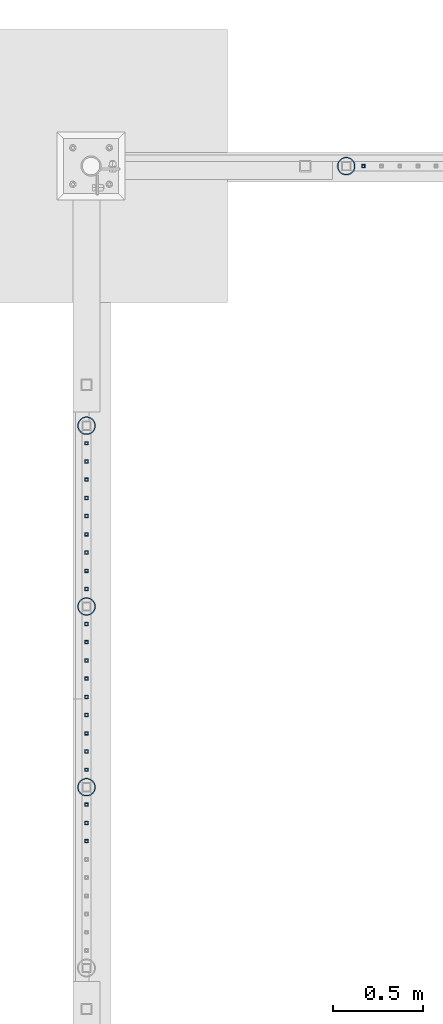
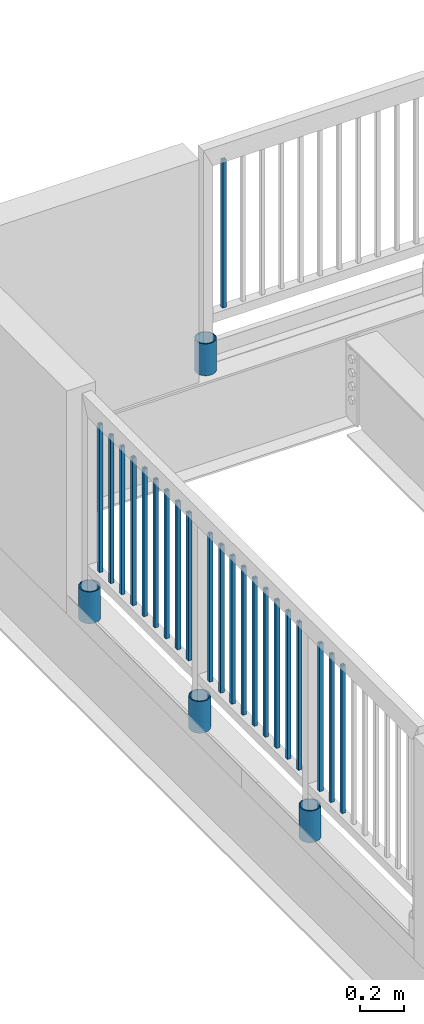
# One storey, part 230 of 975: 26 columns.
"""IFC2X3 building model written with IfcOpenShell, lengths in millimetres."""

from ifc_helpers import new_model, si_unit, frame, origin_with_axes, place, context, subcontext, project, spatial, faceted_brep, material, type_object, element, save


model = new_model("IFC2X3")

# Units and contexts
model_context = context("Model", 3, precision=1e-05, world=origin_with_axes())
body_context = subcontext(model_context, "Body", "Model", "MODEL_VIEW")
ifc_project = project(units=[si_unit("LENGTHUNIT", "METRE", prefix="MILLI"), si_unit("AREAUNIT", "SQUARE_METRE"), si_unit("VOLUMEUNIT", "CUBIC_METRE"), si_unit("MASSUNIT", "GRAM", prefix="KILO"), si_unit("TIMEUNIT", "SECOND"), si_unit("PLANEANGLEUNIT", "RADIAN"), si_unit("SOLIDANGLEUNIT", "STERADIAN"), si_unit("THERMODYNAMICTEMPERATUREUNIT", "DEGREE_CELSIUS"), si_unit("LUMINOUSINTENSITYUNIT", "LUMEN")], contexts=[model_context])

# Site, building, storey
site_placement = place(None, origin_with_axes())
site = spatial("IfcSite", under=ifc_project, at=site_placement, CompositionType="ELEMENT")
building_placement = place(site_placement, origin_with_axes())
building = spatial("IfcBuilding", under=site, at=building_placement, Name="Undefined", CompositionType="ELEMENT")
storey_placement = place(building_placement, origin_with_axes())
storey = spatial("IfcBuildingStorey", under=building, at=storey_placement, Name="Undefined", CompositionType="ELEMENT", Elevation=0.0)

# Columns
ifc_material_1 = material()
column_type_1 = type_object("IfcColumnType", Name="HSS3/4X3/4X.120_TUBES", PredefinedType="NOTDEFINED")
for number, where, z_axis, x_axis, name in (
    (1, (2092.38575337473, 28417.3088163748, 4254.49988162489), (0.0, 1.0, 0.0), (0.0, 0.0, 1.0), "PICKET"),
    (2, (2092.38575337473, 28315.7088163748, 4254.49988162489), (0.0, 1.0, 0.0), (0.0, 0.0, 1.0), "PICKET"),
    (3, (2092.38575337473, 28214.1088163748, 4254.49988162489), (0.0, 1.0, 0.0), (0.0, 0.0, 1.0), "PICKET"),
    (4, (2092.38575337473, 28112.5088163748, 4254.49988162489), (0.0, 1.0, 0.0), (0.0, 0.0, 1.0), "PICKET"),
    (5, (2092.38575337473, 28010.9088163748, 4254.49988162489), (0.0, 1.0, 0.0), (0.0, 0.0, 1.0), "PICKET"),
    (6, (2092.38575337473, 27909.3088163748, 4254.49988162489), (0.0, 1.0, 0.0), (0.0, 0.0, 1.0), "PICKET"),
    (7, (2092.38575337473, 27807.7088163748, 4254.49988162489), (0.0, 1.0, 0.0), (0.0, 0.0, 1.0), "PICKET"),
    (8, (2092.38575337473, 27706.1088163748, 4254.49988162489), (0.0, 1.0, 0.0), (0.0, 0.0, 1.0), "PICKET"),
    (9, (2092.38575337473, 27604.5088163748, 4254.49988162489), (0.0, 1.0, 0.0), (0.0, 0.0, 1.0), "PICKET"),
    (10, (2092.32512607793, 27409.7757252877, 4254.4999510475), (0.0, 1.0, 0.0), (0.0, 0.0, 1.0), "PICKET"),
    (11, (2092.32512607793, 27308.1757252877, 4254.4999510475), (0.0, 1.0, 0.0), (0.0, 0.0, 1.0), "PICKET"),
    (12, (2092.32512607793, 27206.5757252877, 4254.4999510475), (0.0, 1.0, 0.0), (0.0, 0.0, 1.0), "PICKET"),
    (13, (2092.32512607793, 27104.9757252877, 4254.4999510475), (0.0, 1.0, 0.0), (0.0, 0.0, 1.0), "PICKET"),
    (14, (2092.32512607793, 27003.3757252877, 4254.4999510475), (0.0, 1.0, 0.0), (0.0, 0.0, 1.0), "PICKET"),
    (15, (2092.32512607793, 26901.7757252877, 4254.4999510475), (0.0, 1.0, 0.0), (0.0, 0.0, 1.0), "PICKET"),
    (16, (2092.32512607793, 26800.1757252877, 4254.4999510475), (0.0, 1.0, 0.0), (0.0, 0.0, 1.0), "PICKET"),
    (17, (2092.32512607793, 26698.5757252877, 4254.4999510475), (0.0, 1.0, 0.0), (0.0, 0.0, 1.0), "PICKET"),
    (18, (2092.32512607793, 26596.9757252877, 4254.4999510475), (0.0, 1.0, 0.0), (0.0, 0.0, 1.0), "PICKET"),
    (19, (2092.26449887526, 26402.2441986005, 4254.49995104806), (0.0, 1.0, 0.0), (0.0, 0.0, 1.0), "PICKET"),
    (20, (2092.26449887526, 26300.6441986005, 4254.49995104806), (0.0, 1.0, 0.0), (0.0, 0.0, 1.0), "PICKET"),
    (21, (2092.26449887526, 26199.0441986005, 4254.49995104806), (0.0, 1.0, 0.0), (0.0, 0.0, 1.0), "PICKET"),
    (22, (3635.37664058602, 29961.7455061682, 4254.49906094201), (1.0, 0.0, 0.0), (0.0, 0.0, 1.0), "PICKET"),
):
    element("IfcColumn", number, at=place(storey_placement, frame(where, z_axis=z_axis, x_axis=x_axis)), inside=storey, type_object=column_type_1, material=ifc_material_1, Name=name, ObjectType="HSS3/4X3/4X.120_TUBES", context=body_context, shape_type="Brep", body=[
        faceted_brep([(0.0, 6.34999999998763, -6.34999999998763), (0.0, -6.35000000000582, -6.34999999998763), (825.49997943247, -6.35000000000582, -6.34999999998763), (825.49997943247, 6.34999999998763, -6.34999999998763), (0.0, -6.34999999998763, 6.34999999998763), (825.49997943247, -6.34999999998763, 6.34999999998763), (0.0, 6.35000000000946, 6.34999999998763), (825.49997943247, 6.35000000000946, 6.34999999998763), (0.0, 9.52499999997963, -9.52499999997963), (0.0, 9.52500000000873, 9.5249999999869), (825.49997943247, 9.52500000000873, 9.5249999999869), (825.49997943247, 9.52499999997963, -9.52499999997963), (0.0, -9.52499999997963, 9.52499999998327), (825.49997943247, -9.52499999997963, 9.52499999998327), (0.0, -9.52500000000873, -9.5249999999869), (825.49997943247, -9.52500000000873, -9.5249999999869)], [[[0, 1, 2, 3]], [[1, 4, 5, 2]], [[4, 6, 7, 5]], [[6, 0, 3, 7]], [[8, 9, 10, 11]], [[9, 12, 13, 10]], [[12, 14, 15, 13]], [[14, 8, 11, 15]], [[13, 15, 11, 10], [5, 7, 3, 2]], [[14, 12, 9, 8], [6, 4, 1, 0]]]),
    ])
ifc_material_2 = material(Name="STEEL/A53")
column_type_2 = type_object("IfcColumnType", Name="PIPE3-1/2STD", PredefinedType="NOTDEFINED")
column_1_placement = place(storey_placement, frame((2092.32592453032, 26499.6095286945, 3937.0), z_axis=(-0.707106781186601, 0.707106781186494, 2.36468622460961e-14), x_axis=(0.0, 0.0, 1.0)))
element("IfcColumn", 23, at=column_1_placement, inside=storey, type_object=column_type_2, material=ifc_material_2, ObjectType="PIPE3-1/2STD", context=body_context, shape_type="Brep", body=[
    faceted_brep([(0.0, -45.0595999999932, 1.45519152283669e-11), (0.0, -42.8542262016344, 13.924182159768), (177.8, -42.8542262016344, 13.924182159768), (177.8, -45.0595999999932, 1.45519152283669e-11), (0.0, -36.45398215971, 26.4853683542424), (177.8, -36.45398215971, 26.4853683542424), (0.0, -26.4853683541623, 36.45398215979), (177.8, -26.4853683541623, 36.45398215979), (0.0, -13.9241821596988, 42.8542262017108), (177.8, -13.9241821596988, 42.8542262017108), (0.0, 3.63797880709171e-11, 45.0596000000514), (177.8, 3.63797880709171e-11, 45.0596000000514), (0.0, 13.9241821597716, 42.8542262017036), (177.8, 13.9241821597716, 42.8542262017036), (0.0, 26.4853683542242, 36.4539821597718), (177.8, 26.4853683542242, 36.4539821597718), (0.0, 36.4539821597537, 26.4853683542206), (177.8, 36.4539821597537, 26.4853683542206), (0.0, 42.8542262016563, 13.9241821597425), (177.8, 42.8542262016563, 13.9241821597425), (0.0, 45.0595999999932, -1.09139364212751e-11), (177.8, 45.0595999999932, -1.09139364212751e-11), (0.0, 42.8542262016344, -13.9241821597643), (177.8, 42.8542262016344, -13.9241821597643), (0.0, 36.45398215971, -26.4853683542387), (177.8, 36.45398215971, -26.4853683542387), (0.0, 26.4853683541623, -36.4539821597864), (177.8, 26.4853683541623, -36.4539821597864), (0.0, 13.9241821596988, -42.8542262017072), (177.8, 13.9241821596988, -42.8542262017072), (0.0, -3.63797880709171e-11, -45.0596000000478), (177.8, -3.63797880709171e-11, -45.0596000000478), (0.0, -13.9241821597716, -42.8542262016963), (177.8, -13.9241821597716, -42.8542262016963), (0.0, -26.4853683542242, -36.4539821597682), (177.8, -26.4853683542242, -36.4539821597682), (0.0, -36.4539821597537, -26.4853683542169), (177.8, -36.4539821597537, -26.4853683542169), (0.0, -42.8542262016563, -13.9241821597352), (177.8, -42.8542262016563, -13.9241821597352), (0.0, -50.799999999992, 1.81898940354586e-11), (0.0, -48.3136710278013, -15.6980633142484), (177.8, -48.3136710278013, -15.6980633142484), (177.8, -50.799999999992, 1.81898940354586e-11), (0.0, -41.0980633142644, -29.8594908164741), (177.8, -41.0980633142644, -29.8594908164741), (0.0, -29.859490816485, -41.0980633142826), (177.8, -29.859490816485, -41.0980633142826), (0.0, -15.6980633142848, -48.313671027845), (177.8, -15.6980633142848, -48.313671027845), (0.0, -4.36557456851006e-11, -50.8000000000575), (177.8, -4.36557456851006e-11, -50.8000000000575), (0.0, 15.6980633142011, -48.3136710278523), (177.8, 15.6980633142011, -48.3136710278523), (0.0, 29.8594908164159, -41.0980633143045), (177.8, 29.8594908164159, -41.0980633143045), (0.0, 41.0980633142135, -29.8594908165032), (177.8, 41.0980633142135, -29.8594908165032), (0.0, 48.3136710277722, -15.6980633142775), (177.8, 48.3136710277722, -15.6980633142775), (0.0, 50.799999999992, -1.45519152283669e-11), (177.8, 50.799999999992, -1.45519152283669e-11), (0.0, 48.313671027794, 15.6980633142521), (177.8, 48.313671027794, 15.6980633142521), (0.0, 41.0980633142644, 29.8594908164814), (177.8, 41.0980633142644, 29.8594908164814), (0.0, 29.859490816485, 41.0980633142863), (177.8, 29.859490816485, 41.0980633142863), (0.0, 15.6980633142848, 48.3136710278486), (177.8, 15.6980633142848, 48.3136710278486), (0.0, 4.00177668780088e-11, 50.8000000000611), (177.8, 4.00177668780088e-11, 50.8000000000611), (0.0, -15.6980633142011, 48.3136710278559), (177.8, -15.6980633142011, 48.3136710278559), (0.0, -29.8594908164159, 41.0980633143081), (177.8, -29.8594908164159, 41.0980633143081), (0.0, -41.0980633142171, 29.8594908165069), (177.8, -41.0980633142171, 29.8594908165069), (0.0, -48.3136710277722, 15.6980633142812), (177.8, -48.3136710277722, 15.6980633142812)], [[[0, 1, 2, 3]], [[1, 4, 5, 2]], [[4, 6, 7, 5]], [[6, 8, 9, 7]], [[8, 10, 11, 9]], [[10, 12, 13, 11]], [[12, 14, 15, 13]], [[14, 16, 17, 15]], [[16, 18, 19, 17]], [[18, 20, 21, 19]], [[20, 22, 23, 21]], [[22, 24, 25, 23]], [[24, 26, 27, 25]], [[26, 28, 29, 27]], [[28, 30, 31, 29]], [[30, 32, 33, 31]], [[32, 34, 35, 33]], [[34, 36, 37, 35]], [[36, 38, 39, 37]], [[38, 0, 3, 39]], [[40, 41, 42, 43]], [[41, 44, 45, 42]], [[44, 46, 47, 45]], [[46, 48, 49, 47]], [[48, 50, 51, 49]], [[50, 52, 53, 51]], [[52, 54, 55, 53]], [[54, 56, 57, 55]], [[56, 58, 59, 57]], [[58, 60, 61, 59]], [[60, 62, 63, 61]], [[62, 64, 65, 63]], [[64, 66, 67, 65]], [[66, 68, 69, 67]], [[68, 70, 71, 69]], [[70, 72, 73, 71]], [[72, 74, 75, 73]], [[74, 76, 77, 75]], [[76, 78, 79, 77]], [[78, 40, 43, 79]], [[45, 47, 49, 51, 53, 55, 57, 59, 61, 63, 65, 67, 69, 71, 73, 75, 77, 79, 43, 42], [5, 7, 9, 11, 13, 15, 17, 19, 21, 23, 25, 27, 29, 31, 33, 35, 37, 39, 3, 2]], [[78, 76, 74, 72, 70, 68, 66, 64, 62, 60, 58, 56, 54, 52, 50, 48, 46, 44, 41, 40], [38, 36, 34, 32, 30, 28, 26, 24, 22, 20, 18, 16, 14, 12, 10, 8, 6, 4, 1, 0]]]),
])
column_2_placement = place(storey_placement, frame((2092.44294281713, 27507.1418341241, 3937.0), z_axis=(-0.707106781186601, 0.707106781186494, 2.36468622460961e-14), x_axis=(0.0, 0.0, 1.0)))
element("IfcColumn", 24, at=column_2_placement, inside=storey, type_object=column_type_2, material=ifc_material_2, ObjectType="PIPE3-1/2STD", context=body_context, shape_type="Brep", body=[
    faceted_brep([(0.0, -45.0595999999932, 1.45519152283669e-11), (0.0, -42.8542262016344, 13.924182159768), (177.8, -42.8542262016344, 13.924182159768), (177.8, -45.0595999999932, 1.45519152283669e-11), (0.0, -36.45398215971, 26.4853683542424), (177.8, -36.45398215971, 26.4853683542424), (0.0, -26.4853683541623, 36.45398215979), (177.8, -26.4853683541623, 36.45398215979), (0.0, -13.9241821596988, 42.8542262017108), (177.8, -13.9241821596988, 42.8542262017108), (0.0, 3.63797880709171e-11, 45.0596000000514), (177.8, 3.63797880709171e-11, 45.0596000000514), (0.0, 13.9241821597716, 42.8542262017036), (177.8, 13.9241821597716, 42.8542262017036), (0.0, 26.4853683542242, 36.4539821597718), (177.8, 26.4853683542242, 36.4539821597718), (0.0, 36.4539821597537, 26.4853683542206), (177.8, 36.4539821597537, 26.4853683542206), (0.0, 42.8542262016563, 13.9241821597425), (177.8, 42.8542262016563, 13.9241821597425), (0.0, 45.0595999999932, -1.09139364212751e-11), (177.8, 45.0595999999932, -1.09139364212751e-11), (0.0, 42.8542262016344, -13.9241821597643), (177.8, 42.8542262016344, -13.9241821597643), (0.0, 36.45398215971, -26.4853683542387), (177.8, 36.45398215971, -26.4853683542387), (0.0, 26.4853683541623, -36.4539821597864), (177.8, 26.4853683541623, -36.4539821597864), (0.0, 13.9241821596988, -42.8542262017072), (177.8, 13.9241821596988, -42.8542262017072), (0.0, -3.63797880709171e-11, -45.0596000000478), (177.8, -3.63797880709171e-11, -45.0596000000478), (0.0, -13.9241821597716, -42.8542262016963), (177.8, -13.9241821597716, -42.8542262016963), (0.0, -26.4853683542242, -36.4539821597682), (177.8, -26.4853683542242, -36.4539821597682), (0.0, -36.4539821597537, -26.4853683542169), (177.8, -36.4539821597537, -26.4853683542169), (0.0, -42.8542262016563, -13.9241821597352), (177.8, -42.8542262016563, -13.9241821597352), (0.0, -50.799999999992, 1.81898940354586e-11), (0.0, -48.3136710278013, -15.6980633142484), (177.8, -48.3136710278013, -15.6980633142484), (177.8, -50.799999999992, 1.81898940354586e-11), (0.0, -41.0980633142644, -29.8594908164741), (177.8, -41.0980633142644, -29.8594908164741), (0.0, -29.859490816485, -41.0980633142826), (177.8, -29.859490816485, -41.0980633142826), (0.0, -15.6980633142848, -48.313671027845), (177.8, -15.6980633142848, -48.313671027845), (0.0, -4.36557456851006e-11, -50.8000000000575), (177.8, -4.36557456851006e-11, -50.8000000000575), (0.0, 15.6980633142011, -48.3136710278523), (177.8, 15.6980633142011, -48.3136710278523), (0.0, 29.8594908164159, -41.0980633143045), (177.8, 29.8594908164159, -41.0980633143045), (0.0, 41.0980633142135, -29.8594908165032), (177.8, 41.0980633142135, -29.8594908165032), (0.0, 48.3136710277722, -15.6980633142775), (177.8, 48.3136710277722, -15.6980633142775), (0.0, 50.799999999992, -1.45519152283669e-11), (177.8, 50.799999999992, -1.45519152283669e-11), (0.0, 48.313671027794, 15.6980633142521), (177.8, 48.313671027794, 15.6980633142521), (0.0, 41.0980633142644, 29.8594908164814), (177.8, 41.0980633142644, 29.8594908164814), (0.0, 29.859490816485, 41.0980633142863), (177.8, 29.859490816485, 41.0980633142863), (0.0, 15.6980633142848, 48.3136710278486), (177.8, 15.6980633142848, 48.3136710278486), (0.0, 4.00177668780088e-11, 50.8000000000611), (177.8, 4.00177668780088e-11, 50.8000000000611), (0.0, -15.6980633142011, 48.3136710278559), (177.8, -15.6980633142011, 48.3136710278559), (0.0, -29.8594908164159, 41.0980633143081), (177.8, -29.8594908164159, 41.0980633143081), (0.0, -41.0980633142171, 29.8594908165069), (177.8, -41.0980633142171, 29.8594908165069), (0.0, -48.3136710277722, 15.6980633142812), (177.8, -48.3136710277722, 15.6980633142812)], [[[0, 1, 2, 3]], [[1, 4, 5, 2]], [[4, 6, 7, 5]], [[6, 8, 9, 7]], [[8, 10, 11, 9]], [[10, 12, 13, 11]], [[12, 14, 15, 13]], [[14, 16, 17, 15]], [[16, 18, 19, 17]], [[18, 20, 21, 19]], [[20, 22, 23, 21]], [[22, 24, 25, 23]], [[24, 26, 27, 25]], [[26, 28, 29, 27]], [[28, 30, 31, 29]], [[30, 32, 33, 31]], [[32, 34, 35, 33]], [[34, 36, 37, 35]], [[36, 38, 39, 37]], [[38, 0, 3, 39]], [[40, 41, 42, 43]], [[41, 44, 45, 42]], [[44, 46, 47, 45]], [[46, 48, 49, 47]], [[48, 50, 51, 49]], [[50, 52, 53, 51]], [[52, 54, 55, 53]], [[54, 56, 57, 55]], [[56, 58, 59, 57]], [[58, 60, 61, 59]], [[60, 62, 63, 61]], [[62, 64, 65, 63]], [[64, 66, 67, 65]], [[66, 68, 69, 67]], [[68, 70, 71, 69]], [[70, 72, 73, 71]], [[72, 74, 75, 73]], [[74, 76, 77, 75]], [[76, 78, 79, 77]], [[78, 40, 43, 79]], [[45, 47, 49, 51, 53, 55, 57, 59, 61, 63, 65, 67, 69, 71, 73, 75, 77, 79, 43, 42], [5, 7, 9, 11, 13, 15, 17, 19, 21, 23, 25, 27, 29, 31, 33, 35, 37, 39, 3, 2]], [[78, 76, 74, 72, 70, 68, 66, 64, 62, 60, 58, 56, 54, 52, 50, 48, 46, 44, 41, 40], [38, 36, 34, 32, 30, 28, 26, 24, 22, 20, 18, 16, 14, 12, 10, 8, 6, 4, 1, 0]]]),
])
column_3_placement = place(storey_placement, frame((2092.57918437929, 28514.976400217, 3937.0), z_axis=(-0.707106781186601, 0.707106781186494, 2.36468622460961e-14), x_axis=(0.0, 0.0, 1.0)))
element("IfcColumn", 25, at=column_3_placement, inside=storey, type_object=column_type_2, material=ifc_material_2, ObjectType="PIPE3-1/2STD", context=body_context, shape_type="Brep", body=[
    faceted_brep([(0.0, -45.0595999999932, 1.45519152283669e-11), (0.0, -42.8542262016344, 13.924182159768), (177.8, -42.8542262016344, 13.924182159768), (177.8, -45.0595999999932, 1.45519152283669e-11), (0.0, -36.45398215971, 26.4853683542424), (177.8, -36.45398215971, 26.4853683542424), (0.0, -26.4853683541623, 36.45398215979), (177.8, -26.4853683541623, 36.45398215979), (0.0, -13.9241821596988, 42.8542262017108), (177.8, -13.9241821596988, 42.8542262017108), (0.0, 3.63797880709171e-11, 45.0596000000514), (177.8, 3.63797880709171e-11, 45.0596000000514), (0.0, 13.9241821597716, 42.8542262017036), (177.8, 13.9241821597716, 42.8542262017036), (0.0, 26.4853683542242, 36.4539821597718), (177.8, 26.4853683542242, 36.4539821597718), (0.0, 36.4539821597537, 26.4853683542206), (177.8, 36.4539821597537, 26.4853683542206), (0.0, 42.8542262016563, 13.9241821597425), (177.8, 42.8542262016563, 13.9241821597425), (0.0, 45.0595999999932, -1.09139364212751e-11), (177.8, 45.0595999999932, -1.09139364212751e-11), (0.0, 42.8542262016344, -13.9241821597643), (177.8, 42.8542262016344, -13.9241821597643), (0.0, 36.45398215971, -26.4853683542387), (177.8, 36.45398215971, -26.4853683542387), (0.0, 26.4853683541623, -36.4539821597864), (177.8, 26.4853683541623, -36.4539821597864), (0.0, 13.9241821596988, -42.8542262017072), (177.8, 13.9241821596988, -42.8542262017072), (0.0, -3.63797880709171e-11, -45.0596000000478), (177.8, -3.63797880709171e-11, -45.0596000000478), (0.0, -13.9241821597716, -42.8542262016963), (177.8, -13.9241821597716, -42.8542262016963), (0.0, -26.4853683542242, -36.4539821597682), (177.8, -26.4853683542242, -36.4539821597682), (0.0, -36.4539821597537, -26.4853683542169), (177.8, -36.4539821597537, -26.4853683542169), (0.0, -42.8542262016563, -13.9241821597352), (177.8, -42.8542262016563, -13.9241821597352), (0.0, -50.799999999992, 1.81898940354586e-11), (0.0, -48.3136710278013, -15.6980633142484), (177.8, -48.3136710278013, -15.6980633142484), (177.8, -50.799999999992, 1.81898940354586e-11), (0.0, -41.0980633142644, -29.8594908164741), (177.8, -41.0980633142644, -29.8594908164741), (0.0, -29.859490816485, -41.0980633142826), (177.8, -29.859490816485, -41.0980633142826), (0.0, -15.6980633142848, -48.313671027845), (177.8, -15.6980633142848, -48.313671027845), (0.0, -4.36557456851006e-11, -50.8000000000575), (177.8, -4.36557456851006e-11, -50.8000000000575), (0.0, 15.6980633142011, -48.3136710278523), (177.8, 15.6980633142011, -48.3136710278523), (0.0, 29.8594908164159, -41.0980633143045), (177.8, 29.8594908164159, -41.0980633143045), (0.0, 41.0980633142135, -29.8594908165032), (177.8, 41.0980633142135, -29.8594908165032), (0.0, 48.3136710277722, -15.6980633142775), (177.8, 48.3136710277722, -15.6980633142775), (0.0, 50.799999999992, -1.45519152283669e-11), (177.8, 50.799999999992, -1.45519152283669e-11), (0.0, 48.313671027794, 15.6980633142521), (177.8, 48.313671027794, 15.6980633142521), (0.0, 41.0980633142644, 29.8594908164814), (177.8, 41.0980633142644, 29.8594908164814), (0.0, 29.859490816485, 41.0980633142863), (177.8, 29.859490816485, 41.0980633142863), (0.0, 15.6980633142848, 48.3136710278486), (177.8, 15.6980633142848, 48.3136710278486), (0.0, 4.00177668780088e-11, 50.8000000000611), (177.8, 4.00177668780088e-11, 50.8000000000611), (0.0, -15.6980633142011, 48.3136710278559), (177.8, -15.6980633142011, 48.3136710278559), (0.0, -29.8594908164159, 41.0980633143081), (177.8, -29.8594908164159, 41.0980633143081), (0.0, -41.0980633142171, 29.8594908165069), (177.8, -41.0980633142171, 29.8594908165069), (0.0, -48.3136710277722, 15.6980633142812), (177.8, -48.3136710277722, 15.6980633142812)], [[[0, 1, 2, 3]], [[1, 4, 5, 2]], [[4, 6, 7, 5]], [[6, 8, 9, 7]], [[8, 10, 11, 9]], [[10, 12, 13, 11]], [[12, 14, 15, 13]], [[14, 16, 17, 15]], [[16, 18, 19, 17]], [[18, 20, 21, 19]], [[20, 22, 23, 21]], [[22, 24, 25, 23]], [[24, 26, 27, 25]], [[26, 28, 29, 27]], [[28, 30, 31, 29]], [[30, 32, 33, 31]], [[32, 34, 35, 33]], [[34, 36, 37, 35]], [[36, 38, 39, 37]], [[38, 0, 3, 39]], [[40, 41, 42, 43]], [[41, 44, 45, 42]], [[44, 46, 47, 45]], [[46, 48, 49, 47]], [[48, 50, 51, 49]], [[50, 52, 53, 51]], [[52, 54, 55, 53]], [[54, 56, 57, 55]], [[56, 58, 59, 57]], [[58, 60, 61, 59]], [[60, 62, 63, 61]], [[62, 64, 65, 63]], [[64, 66, 67, 65]], [[66, 68, 69, 67]], [[68, 70, 71, 69]], [[70, 72, 73, 71]], [[72, 74, 75, 73]], [[74, 76, 77, 75]], [[76, 78, 79, 77]], [[78, 40, 43, 79]], [[45, 47, 49, 51, 53, 55, 57, 59, 61, 63, 65, 67, 69, 71, 73, 75, 77, 79, 43, 42], [5, 7, 9, 11, 13, 15, 17, 19, 21, 23, 25, 27, 29, 31, 33, 35, 37, 39, 3, 2]], [[78, 76, 74, 72, 70, 68, 66, 64, 62, 60, 58, 56, 54, 52, 50, 48, 46, 44, 41, 40], [38, 36, 34, 32, 30, 28, 26, 24, 22, 20, 18, 16, 14, 12, 10, 8, 6, 4, 1, 0]]]),
])
column_4_placement = place(storey_placement, frame((3540.26362678568, 29961.9991935838, 3937.0), z_axis=(-0.707106781186601, 0.707106781186494, 2.36468622460961e-14), x_axis=(0.0, 0.0, 1.0)))
element("IfcColumn", 26, at=column_4_placement, inside=storey, type_object=column_type_2, material=ifc_material_2, ObjectType="PIPE3-1/2STD", context=body_context, shape_type="Brep", body=[
    faceted_brep([(0.0, -45.0595999999932, 1.45519152283669e-11), (0.0, -42.8542262016344, 13.924182159768), (177.8, -42.8542262016344, 13.924182159768), (177.8, -45.0595999999932, 1.45519152283669e-11), (0.0, -36.45398215971, 26.4853683542424), (177.8, -36.45398215971, 26.4853683542424), (0.0, -26.4853683541623, 36.45398215979), (177.8, -26.4853683541623, 36.45398215979), (0.0, -13.9241821596988, 42.8542262017108), (177.8, -13.9241821596988, 42.8542262017108), (0.0, 3.63797880709171e-11, 45.0596000000514), (177.8, 3.63797880709171e-11, 45.0596000000514), (0.0, 13.9241821597716, 42.8542262017036), (177.8, 13.9241821597716, 42.8542262017036), (0.0, 26.4853683542242, 36.4539821597718), (177.8, 26.4853683542242, 36.4539821597718), (0.0, 36.4539821597537, 26.4853683542206), (177.8, 36.4539821597537, 26.4853683542206), (0.0, 42.8542262016563, 13.9241821597425), (177.8, 42.8542262016563, 13.9241821597425), (0.0, 45.0595999999932, -1.09139364212751e-11), (177.8, 45.0595999999932, -1.09139364212751e-11), (0.0, 42.8542262016344, -13.9241821597643), (177.8, 42.8542262016344, -13.9241821597643), (0.0, 36.45398215971, -26.4853683542387), (177.8, 36.45398215971, -26.4853683542387), (0.0, 26.4853683541623, -36.4539821597864), (177.8, 26.4853683541623, -36.4539821597864), (0.0, 13.9241821596988, -42.8542262017072), (177.8, 13.9241821596988, -42.8542262017072), (0.0, -3.63797880709171e-11, -45.0596000000478), (177.8, -3.63797880709171e-11, -45.0596000000478), (0.0, -13.9241821597716, -42.8542262016963), (177.8, -13.9241821597716, -42.8542262016963), (0.0, -26.4853683542242, -36.4539821597682), (177.8, -26.4853683542242, -36.4539821597682), (0.0, -36.4539821597537, -26.4853683542169), (177.8, -36.4539821597537, -26.4853683542169), (0.0, -42.8542262016563, -13.9241821597352), (177.8, -42.8542262016563, -13.9241821597352), (0.0, -50.799999999992, 1.81898940354586e-11), (0.0, -48.3136710278013, -15.6980633142484), (177.8, -48.3136710278013, -15.6980633142484), (177.8, -50.799999999992, 1.81898940354586e-11), (0.0, -41.0980633142644, -29.8594908164741), (177.8, -41.0980633142644, -29.8594908164741), (0.0, -29.859490816485, -41.0980633142826), (177.8, -29.859490816485, -41.0980633142826), (0.0, -15.6980633142848, -48.313671027845), (177.8, -15.6980633142848, -48.313671027845), (0.0, -4.36557456851006e-11, -50.8000000000575), (177.8, -4.36557456851006e-11, -50.8000000000575), (0.0, 15.6980633142011, -48.3136710278523), (177.8, 15.6980633142011, -48.3136710278523), (0.0, 29.8594908164159, -41.0980633143045), (177.8, 29.8594908164159, -41.0980633143045), (0.0, 41.0980633142135, -29.8594908165032), (177.8, 41.0980633142135, -29.8594908165032), (0.0, 48.3136710277722, -15.6980633142775), (177.8, 48.3136710277722, -15.6980633142775), (0.0, 50.799999999992, -1.45519152283669e-11), (177.8, 50.799999999992, -1.45519152283669e-11), (0.0, 48.313671027794, 15.6980633142521), (177.8, 48.313671027794, 15.6980633142521), (0.0, 41.0980633142644, 29.8594908164814), (177.8, 41.0980633142644, 29.8594908164814), (0.0, 29.859490816485, 41.0980633142863), (177.8, 29.859490816485, 41.0980633142863), (0.0, 15.6980633142848, 48.3136710278486), (177.8, 15.6980633142848, 48.3136710278486), (0.0, 4.00177668780088e-11, 50.8000000000611), (177.8, 4.00177668780088e-11, 50.8000000000611), (0.0, -15.6980633142011, 48.3136710278559), (177.8, -15.6980633142011, 48.3136710278559), (0.0, -29.8594908164159, 41.0980633143081), (177.8, -29.8594908164159, 41.0980633143081), (0.0, -41.0980633142171, 29.8594908165069), (177.8, -41.0980633142171, 29.8594908165069), (0.0, -48.3136710277722, 15.6980633142812), (177.8, -48.3136710277722, 15.6980633142812)], [[[0, 1, 2, 3]], [[1, 4, 5, 2]], [[4, 6, 7, 5]], [[6, 8, 9, 7]], [[8, 10, 11, 9]], [[10, 12, 13, 11]], [[12, 14, 15, 13]], [[14, 16, 17, 15]], [[16, 18, 19, 17]], [[18, 20, 21, 19]], [[20, 22, 23, 21]], [[22, 24, 25, 23]], [[24, 26, 27, 25]], [[26, 28, 29, 27]], [[28, 30, 31, 29]], [[30, 32, 33, 31]], [[32, 34, 35, 33]], [[34, 36, 37, 35]], [[36, 38, 39, 37]], [[38, 0, 3, 39]], [[40, 41, 42, 43]], [[41, 44, 45, 42]], [[44, 46, 47, 45]], [[46, 48, 49, 47]], [[48, 50, 51, 49]], [[50, 52, 53, 51]], [[52, 54, 55, 53]], [[54, 56, 57, 55]], [[56, 58, 59, 57]], [[58, 60, 61, 59]], [[60, 62, 63, 61]], [[62, 64, 65, 63]], [[64, 66, 67, 65]], [[66, 68, 69, 67]], [[68, 70, 71, 69]], [[70, 72, 73, 71]], [[72, 74, 75, 73]], [[74, 76, 77, 75]], [[76, 78, 79, 77]], [[78, 40, 43, 79]], [[45, 47, 49, 51, 53, 55, 57, 59, 61, 63, 65, 67, 69, 71, 73, 75, 77, 79, 43, 42], [5, 7, 9, 11, 13, 15, 17, 19, 21, 23, 25, 27, 29, 31, 33, 35, 37, 39, 3, 2]], [[78, 76, 74, 72, 70, 68, 66, 64, 62, 60, 58, 56, 54, 52, 50, 48, 46, 44, 41, 40], [38, 36, 34, 32, 30, 28, 26, 24, 22, 20, 18, 16, 14, 12, 10, 8, 6, 4, 1, 0]]]),
])

save(model, "model.ifc")
